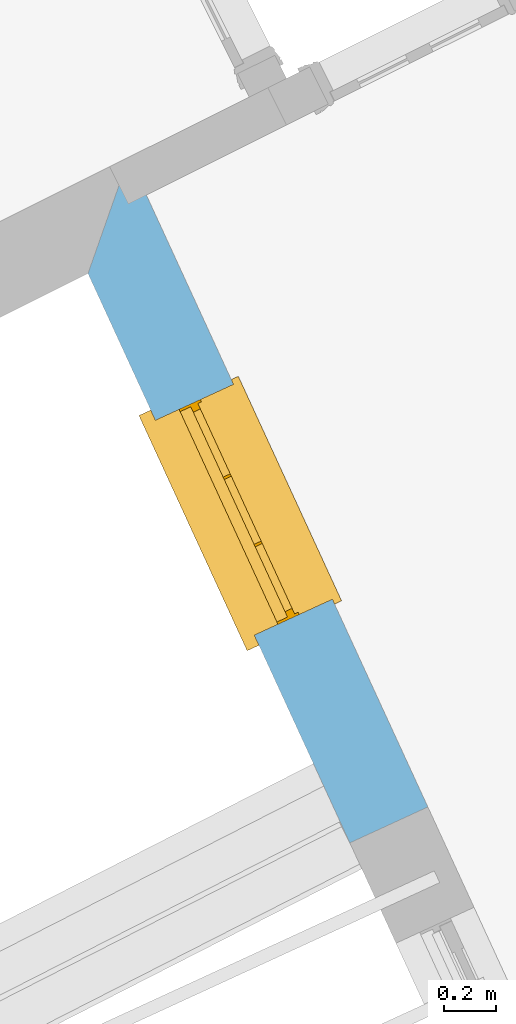
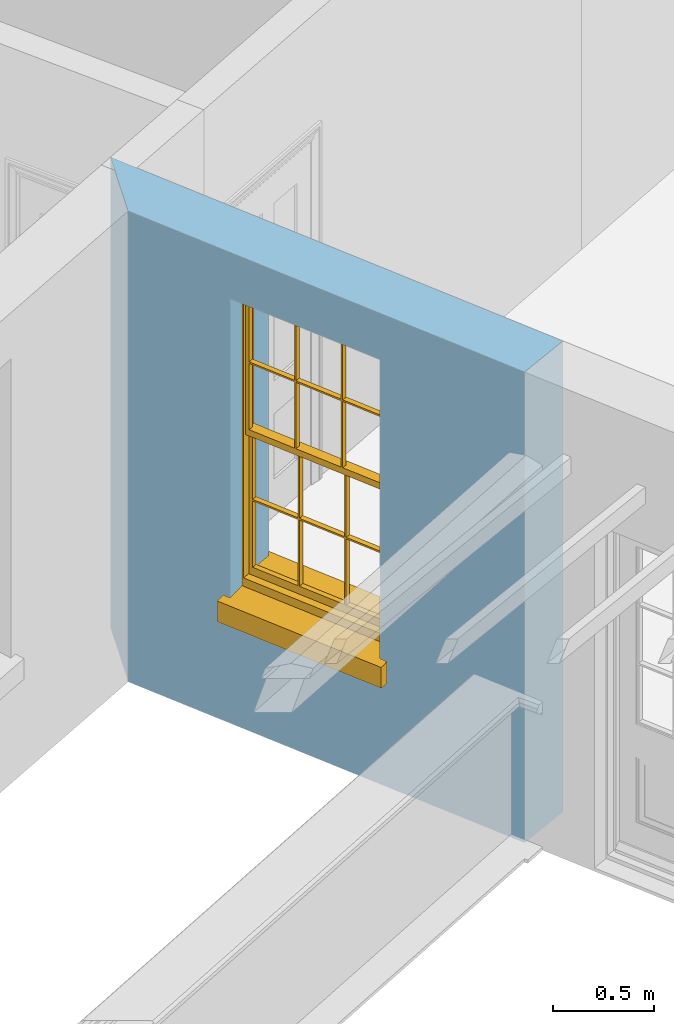
# One storey, part 3 of 9: 1 window, 1 opening, plus 1 element that does not belong to this part.
"""IFC2X3 building model written with IfcOpenShell, lengths in metres."""

from ifc_helpers import new_model, si_unit, frame, origin, place, context, subcontext, project, spatial, polyline, outline, extrude, faceted_brep, material, layer, layer_set, layer_usage, element, fill, save


model = new_model("IFC2X3")

# Units and contexts
model_context = context("Model", 3, world=origin())
body_context = subcontext(model_context, "Body", "Model", "MODEL_VIEW")
ifc_project = project(units=[si_unit("PLANEANGLEUNIT", "RADIAN"), si_unit("MASSUNIT", "GRAM", prefix="KILO"), si_unit("FORCEUNIT", "NEWTON", prefix="KILO"), si_unit("LENGTHUNIT", "METRE")], contexts=[model_context])

# Site, building, storey
site_placement = place(None, origin())
site = spatial("IfcSite", under=ifc_project, at=site_placement, CompositionType="ELEMENT")
building_placement = place(None, origin())
building = spatial("IfcBuilding", under=site, at=building_placement, Name="Building plot-8", CompositionType="ELEMENT")
storey_placement = place(None, frame((0.0, 0.0, 3.45)))
storey = spatial("IfcBuildingStorey", under=building, at=storey_placement, Name="Floor 1", CompositionType="ELEMENT", Elevation=3.45)

# Wall, opening, window
ifc_material = material(Name="Masonry")
ifc_layer = layer(ifc_material, 0.33, ventilated=False)
ifc_layer_set = layer_set([ifc_layer], Name="My Wall")
ifc_layer_usage = layer_usage(ifc_layer_set, "AXIS2", "NEGATIVE", 0.08)
wall_placement = place(storey_placement, origin())
wall = element("IfcWallStandardCase", 1, at=wall_placement, inside=storey, material=ifc_layer_usage, Name="exterior", context=body_context, shape_type="SweptSolid", body=[
    extrude(outline(polyline([(23.8378385127795, 13.1585845025615), (23.6804146792413, 12.7111519511387), (24.6869722630542, 10.5229389293337), (24.9867751738983, 10.6608454725049), (23.8378385127795, 13.1585845025615)])), origin(), (0.0, 0.0, 1.0), 2.85),
])
opening_placement = place(storey_placement, frame((0.0, 0.0, 0.75)))
opening = element("IfcOpeningElement", 2, at=opening_placement, cuts=wall, Name="Opening", ObjectType="Opening", context=body_context, shape_type="SweptSolid", body=[
    extrude(outline(polyline([(23.9396181323413, 12.1476547598287), (24.3199058726013, 11.3209255208344), (24.6197087834453, 11.4588320640056), (24.2394210431854, 12.2855613029998), (23.9396181323413, 12.1476547598287)])), origin(), (0.0, 0.0, 1.0), 1.82),
])
window_placement = place(storey_placement, frame((24.1667415496474, 12.2521294137462, 0.75), z_axis=(0.0, 0.0, 1.0), x_axis=(0.380287740259927, -0.826729238994242, 0.0)))
window = element("IfcWindow", 3, at=window_placement, inside=storey, Name="living outside window", OverallHeight=1.82, OverallWidth=0.91, context=body_context, shape_type="Brep", held_by="IfcProductRepresentation", body=[
    faceted_brep([(0.033125, -0.105, 0.975209), (0.01, -0.105, 0.975209), (0.033125, -0.105, 1.376042), (0.876875, -0.105, 0.975209), (0.876875, -0.105, 1.376042), (0.9, -0.105, 0.975209), (0.876875, -0.105, 1.386042), (0.876875, -0.105, 1.786875), (0.9, -0.105, 1.81), (0.033125, -0.105, 1.786875), (0.033125, -0.105, 1.386042), (0.01, -0.105, 1.81), (0.876875, -0.135, 1.376042), (0.876875, -0.135, 0.975209), (0.9, -0.135, 0.937083), (0.033125, -0.135, 1.786875), (0.01, -0.135, 1.81), (0.033125, -0.135, 1.386042), (0.01, -0.135, 0.937083), (0.033125, -0.135, 0.975209), (0.033125, -0.135, 1.376042), (0.876875, -0.135, 1.786875), (0.876875, -0.135, 1.386042), (0.9, -0.135, 1.81), (0.033125, -0.105, 0.937083), (0.01, -0.105, 0.937083), (0.033125, -0.105, 0.53625), (0.876875, -0.105, 0.937083), (0.876875, -0.105, 0.53625), (0.9, -0.105, 0.937083), (0.876875, -0.105, 0.52625), (0.876875, -0.105, 0.125417), (0.9, -0.105, 0.077167), (0.033125, -0.105, 0.125417), (0.033125, -0.105, 0.52625), (0.01, -0.105, 0.077167), (-0.0425, -0.25, 0.01), (-0.0425, -0.3, 0.001667), (0.0, -0.25, 0.01), (0.9525, -0.25, 0.01), (0.91, -0.25, 0.01), (0.9525, -0.3, 0.001667), (-0.02, 0.08, 0.077167), (0.0, 0.08, 0.077167), (-0.02, 0.11, 0.077167), (0.0, -0.06, 0.077167), (0.01, -0.06, 0.077167), (0.91, -0.06, 0.077167), (0.91, 0.08, 0.077167), (0.9, -0.06, 0.077167), (0.93, 0.08, 0.077167), (0.93, 0.11, 0.077167), (0.01, -0.075, 0.975209), (0.9, -0.075, 0.975209), (0.876875, -0.075, 0.125417), (0.876875, -0.075, 0.52625), (0.9, -0.075, 0.077167), (0.876875, -0.075, 0.53625), (0.876875, -0.075, 0.937083), (0.033125, -0.075, 0.125417), (0.01, -0.075, 0.077167), (0.033125, -0.075, 0.52625), (0.033125, -0.075, 0.937083), (0.033125, -0.075, 0.53625), (-0.02, 0.08, 0.052167), (-0.02, 0.11, 0.052167), (0.93, 0.11, 0.052167), (0.93, 0.08, 0.052167), (0.91, 0.08, 0.052167), (0.0, 0.08, 0.052167), (0.91, -0.15, 0.026667), (0.0, -0.15, 0.026667), (-0.0425, -0.3, -0.123333), (0.9525, -0.3, -0.123333), (-0.0425, -0.25, -0.123333), (0.9525, -0.25, -0.123333), (0.01, -0.06, 1.81), (0.9, -0.06, 1.81), (0.0, -0.06, 1.82), (0.91, -0.06, 1.82), (0.01, -0.15, 0.077167), (0.9, -0.15, 0.077167), (0.592292, -0.105, 0.125417), (0.592292, -0.075, 0.125417), (0.317708, -0.075, 0.125417), (0.317708, -0.105, 0.125417), (0.592292, -0.105, 0.53625), (0.317708, -0.105, 0.53625), (0.317708, -0.105, 0.52625), (0.592292, -0.105, 0.52625), (0.592292, -0.075, 0.53625), (0.317708, -0.075, 0.53625), (0.592292, -0.135, 1.386042), (0.592292, -0.105, 1.386042), (0.317708, -0.105, 1.386042), (0.317708, -0.135, 1.386042), (0.317708, -0.135, 1.376042), (0.592292, -0.135, 1.376042), (0.317708, -0.105, 1.376042), (0.592292, -0.105, 1.376042), (0.602292, -0.135, 1.376042), (0.592292, -0.135, 0.975209), (0.602292, -0.135, 0.975209), (0.602292, -0.105, 0.975209), (0.592292, -0.105, 0.975209), (0.602292, -0.105, 1.376042), (0.602292, -0.075, 0.53625), (0.602292, -0.105, 0.53625), (0.317708, -0.075, 0.52625), (0.307708, -0.075, 0.125417), (0.307708, -0.075, 0.52625), (0.602292, -0.075, 0.52625), (0.602292, -0.075, 0.125417), (0.592292, -0.075, 0.52625), (0.307708, -0.075, 0.53625), (0.317708, -0.075, 0.937083), (0.307708, -0.075, 0.937083), (0.602292, -0.075, 0.937083), (0.592292, -0.075, 0.937083), (0.307708, -0.105, 0.52625), (0.307708, -0.105, 0.125417), (0.307708, -0.105, 0.53625), (0.307708, -0.105, 0.937083), (0.592292, -0.105, 0.937083), (0.317708, -0.105, 0.937083), (0.602292, -0.105, 0.937083), (0.602292, -0.105, 0.52625), (0.602292, -0.105, 0.125417), (0.307708, -0.135, 1.386042), (0.307708, -0.135, 1.376042), (0.307708, -0.135, 0.975209), (0.317708, -0.135, 0.975209), (0.317708, -0.135, 1.786875), (0.307708, -0.135, 1.786875), (0.602292, -0.135, 1.786875), (0.592292, -0.135, 1.786875), (0.602292, -0.135, 1.386042), (0.602292, -0.105, 1.386042), (0.307708, -0.105, 1.386042), (0.307708, -0.105, 1.786875), (0.317708, -0.105, 1.786875), (0.592292, -0.105, 1.786875), (0.602292, -0.105, 1.786875), (0.307708, -0.105, 1.376042), (0.317708, -0.105, 0.975209), (0.307708, -0.105, 0.975209), (0.91, -0.15, 1.82), (0.9, -0.15, 1.81), (0.01, -0.15, 1.81), (0.0, -0.15, 1.82), (0.91, -0.25, 0.0), (0.0, -0.25, 0.0), (0.91, 0.08, 0.0), (0.0, 0.08, 0.0)], [[[0, 1, 2]], [[3, 4, 5]], [[6, 7, 8]], [[9, 10, 11]], [[12, 13, 14]], [[15, 16, 17]], [[18, 19, 20]], [[21, 22, 23]], [[24, 25, 26]], [[27, 28, 29]], [[30, 31, 32]], [[33, 34, 35]], [[14, 27, 29]], [[25, 24, 18]], [[36, 37, 38]], [[39, 40, 41]], [[42, 43, 44]], [[45, 46, 43]], [[47, 48, 49]], [[50, 51, 48]], [[1, 0, 52]], [[5, 53, 3]], [[54, 55, 56]], [[57, 58, 53]], [[59, 60, 61]], [[62, 63, 52]], [[48, 43, 46, 49]], [[51, 44, 43, 48]], [[64, 42, 44, 65]], [[65, 44, 51, 66]], [[66, 51, 50, 67]], [[65, 66, 68, 69]], [[60, 56, 49, 46]], [[70, 71, 38, 40]], [[37, 41, 40, 38]], [[37, 72, 73, 41]], [[74, 75, 73, 72]], [[8, 11, 76, 77]], [[76, 78, 79, 77]], [[32, 35, 80, 81]], [[81, 80, 71, 70]], [[82, 83, 84, 85]], [[86, 87, 88, 89]], [[86, 90, 91, 87]], [[92, 93, 94, 95]], [[92, 95, 96, 97]], [[96, 98, 99, 97]], [[100, 97, 101, 102]], [[103, 104, 99, 105]], [[97, 99, 104, 101]], [[102, 103, 105, 100]], [[28, 57, 106, 107]], [[108, 84, 109, 110]], [[111, 112, 83, 113]], [[114, 110, 61, 63]], [[90, 113, 108, 91]], [[115, 91, 114, 116]], [[117, 106, 90, 118]], [[111, 106, 57, 55]], [[119, 110, 109, 120]], [[34, 61, 110, 119]], [[89, 113, 83, 82]], [[88, 108, 113, 89]], [[85, 84, 108, 88]], [[121, 114, 63, 26]], [[122, 116, 114, 121]], [[123, 118, 90, 86]], [[87, 91, 115, 124]], [[107, 106, 117, 125]], [[126, 111, 55, 30]], [[127, 112, 111, 126]], [[126, 30, 28, 107]], [[88, 119, 120, 85]], [[126, 89, 82, 127]], [[125, 123, 86, 107]], [[121, 26, 34, 119]], [[124, 122, 121, 87]], [[128, 17, 20, 129]], [[96, 129, 130, 131]], [[132, 133, 128, 95]], [[134, 135, 92, 136]], [[100, 12, 22, 136]], [[137, 6, 4, 105]], [[94, 138, 139, 140]], [[137, 93, 141, 142]], [[99, 98, 94, 93]], [[143, 2, 10, 138]], [[144, 145, 143, 98]], [[129, 143, 145, 130]], [[20, 2, 143, 129]], [[131, 144, 98, 96]], [[128, 138, 10, 17]], [[133, 139, 138, 128]], [[135, 141, 93, 92]], [[95, 94, 140, 132]], [[22, 6, 137, 136]], [[136, 137, 142, 134]], [[100, 105, 4, 12]], [[107, 86, 89, 126]], [[106, 111, 113, 90]], [[91, 108, 110, 114]], [[87, 121, 119, 88]], [[97, 100, 136, 92]], [[129, 96, 95, 128]], [[98, 143, 138, 94]], [[105, 99, 93, 137]], [[131, 101, 104, 144]], [[124, 115, 118, 123]], [[132, 140, 141, 135]], [[120, 109, 59, 33]], [[15, 9, 139, 133]], [[134, 142, 7, 21]], [[31, 54, 112, 127]], [[36, 74, 72, 37]], [[39, 41, 73, 75]], [[18, 14, 101, 131]], [[23, 16, 132, 135]], [[83, 56, 60, 84]], [[52, 53, 118, 115]], [[53, 52, 144, 104]], [[11, 8, 141, 140]], [[14, 18, 124, 123]], [[2, 1, 11, 10]], [[8, 5, 4, 6]], [[57, 53, 56, 55]], [[60, 52, 63, 61]], [[26, 25, 35, 34]], [[32, 29, 28, 30]], [[14, 23, 22, 12]], [[18, 20, 17, 16]], [[19, 0, 2, 20]], [[17, 10, 9, 15]], [[12, 4, 3, 13]], [[21, 7, 6, 22]], [[27, 58, 57, 28]], [[30, 55, 54, 31]], [[33, 59, 61, 34]], [[26, 63, 62, 24]], [[5, 8, 77, 53]], [[76, 11, 1, 52]], [[46, 45, 78, 76]], [[49, 77, 79, 47]], [[70, 146, 147, 81]], [[71, 80, 148, 149]], [[19, 130, 145, 0]], [[102, 13, 3, 103]], [[116, 122, 24, 62]], [[29, 32, 81, 14]], [[80, 35, 25, 18]], [[60, 46, 76, 52]], [[77, 49, 56, 53]], [[23, 14, 81, 147]], [[16, 148, 80, 18]], [[35, 85, 120]], [[120, 33, 35]], [[127, 82, 32]], [[32, 31, 127]], [[32, 82, 85, 35]], [[102, 101, 14]], [[14, 13, 102]], [[18, 131, 130]], [[130, 19, 18]], [[134, 21, 23]], [[23, 135, 134]], [[16, 15, 133]], [[133, 132, 16]], [[11, 140, 139]], [[139, 9, 11]], [[142, 141, 8]], [[8, 7, 142]], [[23, 147, 148, 16]], [[146, 149, 148, 147]], [[52, 115, 116]], [[116, 62, 52]], [[118, 53, 117]], [[58, 117, 53]], [[27, 125, 117, 58]], [[56, 83, 112]], [[112, 54, 56]], [[109, 84, 60]], [[60, 59, 109]], [[125, 27, 14]], [[14, 123, 125]], [[122, 124, 18]], [[18, 24, 122]], [[145, 144, 52]], [[52, 0, 145]], [[103, 3, 53]], [[53, 104, 103]], [[79, 78, 149, 146]], [[78, 45, 71, 149]], [[146, 70, 47, 79]], [[150, 75, 74, 151]], [[68, 66, 67]], [[48, 68, 67, 50]], [[69, 64, 65]], [[42, 64, 69, 43]], [[69, 68, 152, 153]], [[70, 68, 48, 47]], [[150, 152, 68, 70]], [[43, 69, 71, 45]], [[69, 153, 151, 71]], [[152, 150, 151, 153]], [[38, 151, 74, 36]], [[71, 151, 38]], [[39, 75, 150, 40]], [[40, 150, 70]]]),
])
fill(opening, window)

save(model, "model.ifc")
